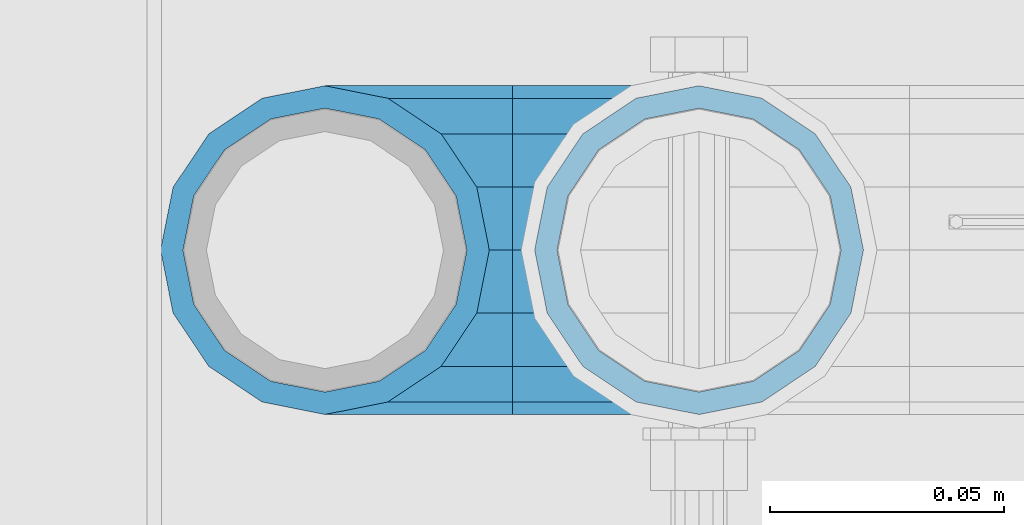
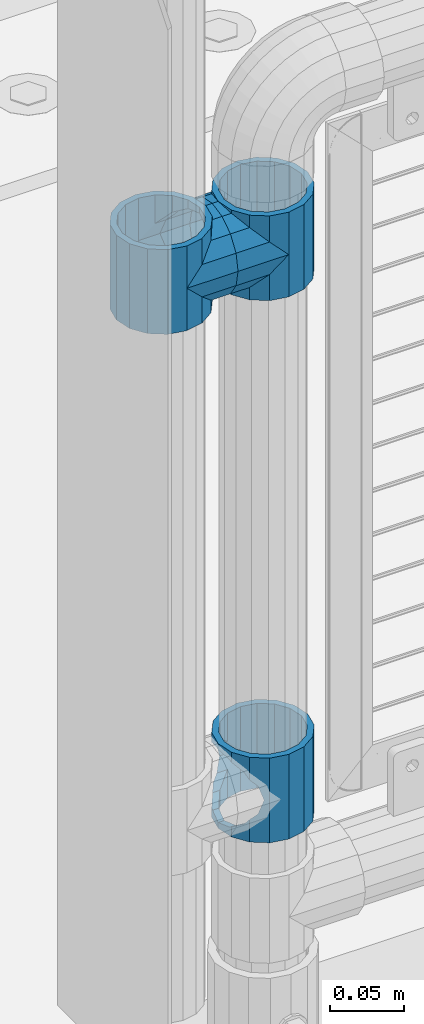
# One storey, part 109 of 193: 5 beams.
"""IFC2X3 building model written with IfcOpenShell, lengths in millimetres."""

from ifc_helpers import new_model, si_unit, frame, origin_with_axes, place, context, subcontext, project, spatial, faceted_brep, material, type_object, element, save


model = new_model("IFC2X3")

# Units and contexts
model_context = context("Model", 3, precision=1e-05, world=origin_with_axes())
body_context = subcontext(model_context, "Body", "Model", "MODEL_VIEW")
ifc_project = project(units=[si_unit("LENGTHUNIT", "METRE", prefix="MILLI"), si_unit("AREAUNIT", "SQUARE_METRE"), si_unit("VOLUMEUNIT", "CUBIC_METRE"), si_unit("MASSUNIT", "GRAM", prefix="KILO"), si_unit("TIMEUNIT", "SECOND"), si_unit("PLANEANGLEUNIT", "RADIAN"), si_unit("SOLIDANGLEUNIT", "STERADIAN"), si_unit("THERMODYNAMICTEMPERATUREUNIT", "DEGREE_CELSIUS"), si_unit("LUMINOUSINTENSITYUNIT", "LUMEN")], contexts=[model_context])

# Site, building, storey
site_placement = place(None, origin_with_axes())
site = spatial("IfcSite", under=ifc_project, at=site_placement, CompositionType="ELEMENT")
building_placement = place(site_placement, origin_with_axes())
building = spatial("IfcBuilding", under=site, at=building_placement, Name="Standard", CompositionType="ELEMENT")
storey_placement = place(building_placement, origin_with_axes())
storey = spatial("IfcBuildingStorey", under=building, at=storey_placement, Name="Undefined", CompositionType="ELEMENT", Elevation=0.0)

# Beams
ifc_material = material(Name="Misc_Undefined")
beam_type = type_object("IfcBeamType", PredefinedType="NOTDEFINED")
beam_1_placement = place(storey_placement, frame((-41829.0, 28664.5, 433.820000000004), z_axis=(1.0, 0.0, 0.0), x_axis=(0.0, 0.0, -1.0)))
element("IfcBeam", 1, at=beam_1_placement, inside=storey, type_object=beam_type, material=ifc_material, context=body_context, shape_type="Brep", body=[
    faceted_brep([(46.7644421722801, 28.0397438117179, -11.614442172282), (46.7644421722801, 28.0397438117179, -20.0882031229849), (51.5310424080006, 24.8548033587067, -24.8548033587067), (56.6106908090114, 21.46069080901, -27.1226768591041), (56.6106908090114, 21.46069080901, -21.46069080901), (61.9623795176744, 13.4513226476338, -32.4743655677703), (63.1897438117172, 11.614442172282, -32.8397438117245), (63.1897438117172, 11.614442172282, -28.0397438117179), (65.4999999999997, 0.0, -35.1500000000015), (65.4999999999997, 0.0, -30.3499999999985), (63.1897438117172, -11.614442172282, -32.8397438117172), (63.1897438117172, -11.614442172282, -28.0397438117179), (61.9623795176767, -13.4513226476338, -32.4743655677703), (56.6106908090114, -21.46069080901, -27.1226768591114), (56.6106908090114, -21.46069080901, -21.46069080901), (51.5310424080006, -24.8548033587067, -24.8548033587067), (46.7644421722801, -28.0397438117179, -20.0882031229812), (46.7644421722801, -28.0397438117179, -11.614442172282), (35.1499999999996, -30.3499999999985, -16.6306603983721), (35.1500000000015, -30.35, 0.0), (23.5355578277191, -28.0397438117179, -20.0882031229812), (23.5355578277191, -28.0397438117179, -11.614442172282), (18.7689575919921, -24.8548033587067, -24.8548033587067), (13.6893091909879, -21.46069080901, -27.1226768591114), (13.6893091909879, -21.46069080901, -21.46069080901), (8.33762048232484, -13.4513226476338, -32.4743655677703), (7.11025618828211, -11.614442172282, -32.8397438117172), (7.11025618828211, -11.614442172282, -28.0397438117179), (4.79999999999961, 0.0, -35.1500000000015), (4.79999999999961, 0.0, -30.3499999999985), (7.11025618828211, 11.614442172282, -32.8397438117245), (7.11025618828211, 11.614442172282, -28.0397438117179), (8.33762048232262, 13.4513226476338, -32.4743655677703), (13.6893091909879, 21.46069080901, -27.1226768591041), (13.6893091909879, 21.46069080901, -21.46069080901), (18.7689575919987, 24.8548033587067, -24.8548033587067), (23.5355578277192, 28.0397438117179, -20.0882031229849), (23.5355578277192, 28.0397438117179, -11.614442172282), (35.1499999999996, 30.3499999999985, -16.6306603983685), (35.1500000000015, 30.35, 0.0), (0.0, 32.4743655677703, -13.4513226476338), (0.0, 35.1500000000015, 0.0), (70.2999999999993, 35.1500000000015, 0.0), (70.2999999999993, 32.4743655677703, -13.4513226476338), (0.0, 32.4743655677703, 13.4513226476338), (70.2999999999993, 32.4743655677703, 13.4513226476338), (0.0, 24.8548033587067, 24.8548033587067), (70.2999999999993, 24.8548033587067, 24.8548033587067), (0.0, 13.4513226476338, 32.4743655677703), (70.2999999999993, 13.4513226476338, 32.4743655677703), (0.0, 0.0, 35.1500000000015), (70.2999999999993, 0.0, 35.1500000000015), (0.0, -13.4513226476338, 32.4743655677703), (70.2999999999993, -13.4513226476338, 32.4743655677703), (0.0, -24.8548033587067, 24.8548033587067), (70.2999999999993, -24.8548033587067, 24.8548033587067), (0.0, -32.4743655677703, 13.4513226476338), (70.2999999999993, -32.4743655677703, 13.4513226476338), (0.0, -35.1500000000015, 0.0), (70.2999999999993, -35.1500000000015, 0.0), (70.2999999999993, -30.3499999999985, 0.0), (70.2999999999993, -28.0397438117179, -11.614442172282), (70.2999999999993, -21.46069080901, -21.46069080901), (70.2999999999993, -11.614442172282, -28.0397438117179), (70.2999999999993, 0.0, -30.3499999999985), (70.2999999999993, 11.614442172282, -28.0397438117179), (70.2999999999993, 21.46069080901, -21.46069080901), (70.2999999999993, 28.0397438117179, -11.614442172282), (0.0, -28.0397438117179, -11.614442172282), (0.0, -30.3499999999985, 0.0), (0.0, -21.46069080901, -21.46069080901), (0.0, -11.614442172282, -28.0397438117179), (0.0, 0.0, -30.3499999999985), (0.0, 11.614442172282, -28.0397438117179), (0.0, 21.46069080901, -21.46069080901), (0.0, 28.0397438117179, -11.614442172282), (0.0, 30.3499999999985, 0.0), (70.2999999999993, 30.3499999999985, 0.0), (0.0, 28.0397438117179, 11.614442172282), (70.2999999999993, 28.0397438117179, 11.614442172282), (0.0, 21.46069080901, 21.46069080901), (70.2999999999993, 21.46069080901, 21.46069080901), (0.0, 11.614442172282, 28.0397438117179), (70.2999999999993, 11.614442172282, 28.0397438117179), (0.0, 0.0, 30.3499999999985), (70.2999999999993, 0.0, 30.3499999999985), (0.0, -11.614442172282, 28.0397438117179), (70.2999999999993, -11.614442172282, 28.0397438117179), (0.0, -21.46069080901, 21.46069080901), (70.2999999999993, -21.46069080901, 21.46069080901), (0.0, -28.0397438117179, 11.614442172282), (70.2999999999993, -28.0397438117179, 11.614442172282), (70.2999999999993, -24.8548033587067, -24.8548033587067), (70.2999999999993, -13.4513226476338, -32.4743655677703), (70.2999999999993, 0.0, -35.1500000000015), (70.2999999999993, 13.4513226476338, -32.4743655677703), (70.2999999999993, 24.8548033587067, -24.8548033587067), (70.2999999999993, -32.4743655677703, -13.4513226476338), (0.0, -32.4743655677703, -13.4513226476338), (0.0, 24.8548033587067, -24.8548033587067), (0.0, 13.4513226476338, -32.4743655677703), (0.0, 0.0, -35.1500000000015), (0.0, -13.4513226476338, -32.4743655677703), (0.0, -24.8548033587067, -24.8548033587067)], [[[0, 1, 2, 3, 4]], [[4, 3, 5, 6, 7]], [[7, 6, 8, 9]], [[9, 8, 10, 11]], [[11, 10, 12, 13, 14]], [[14, 13, 15, 16, 17]], [[17, 16, 18, 19]], [[19, 18, 20, 21]], [[21, 20, 22, 23, 24]], [[24, 23, 25, 26, 27]], [[27, 26, 28, 29]], [[29, 28, 30, 31]], [[31, 30, 32, 33, 34]], [[34, 33, 35, 36, 37]], [[37, 36, 38, 39]], [[39, 38, 1, 0]], [[40, 41, 42, 43]], [[41, 44, 45, 42]], [[44, 46, 47, 45]], [[46, 48, 49, 47]], [[48, 50, 51, 49]], [[50, 52, 53, 51]], [[52, 54, 55, 53]], [[54, 56, 57, 55]], [[56, 58, 59, 57]], [[60, 61, 17, 19]], [[61, 62, 14, 17]], [[62, 63, 11, 14]], [[63, 64, 9, 11]], [[64, 65, 7, 9]], [[65, 66, 4, 7]], [[66, 67, 0, 4]], [[68, 69, 19, 21]], [[70, 68, 21, 24]], [[71, 70, 24, 27]], [[72, 71, 27, 29]], [[73, 72, 29, 31]], [[74, 73, 31, 34]], [[75, 74, 34, 37]], [[76, 75, 37, 39]], [[67, 77, 39, 0]], [[78, 76, 39, 77, 79]], [[80, 78, 79, 81]], [[82, 80, 81, 83]], [[84, 82, 83, 85]], [[86, 84, 85, 87]], [[88, 86, 87, 89]], [[90, 88, 89, 91]], [[19, 69, 90, 91, 60]], [[92, 93, 94, 95, 96, 43, 42, 45, 47, 49, 51, 53, 55, 57, 59, 97], [89, 87, 85, 83, 81, 79, 77, 67, 66, 65, 64, 63, 62, 61, 60, 91]], [[58, 98, 97, 59]], [[56, 54, 52, 50, 48, 46, 44, 41, 40, 99, 100, 101, 102, 103, 98, 58], [68, 70, 71, 72, 73, 74, 75, 76, 78, 80, 82, 84, 86, 88, 90, 69]], [[32, 100, 99, 35, 33]], [[28, 101, 100, 32, 30]], [[102, 101, 28, 26, 25]], [[103, 102, 25, 23, 22]], [[15, 92, 97, 98, 103, 22, 20, 18, 16]], [[12, 93, 92, 15, 13]], [[8, 94, 93, 12, 10]], [[95, 94, 8, 6, 5]], [[96, 95, 5, 3, 2]], [[35, 99, 40, 43, 96, 2, 1, 38, 36]]]),
])
beam_2_placement = place(storey_placement, frame((-41909.0, 28664.5, 848.670000000005), z_axis=(0.0, -1.0, 0.0), x_axis=(1.0, 0.0, 0.0)))
element("IfcBeam", 2, at=beam_2_placement, inside=storey, type_object=beam_type, material=ifc_material, context=body_context, shape_type="Brep", body=[
    faceted_brep([(0.0, 0.0, -35.1500000000015), (13.4513226476338, -13.4513226476329, -32.4743655677703), (13.4513226476338, 13.4513226476329, -32.4743655677703), (32.4743655677703, 32.4743655677717, 13.4513226476338), (32.4743655677703, 26.8123795176754, 13.4513226476338), (27.1226768591041, 21.4606908090117, 21.46069080901), (24.8548033587067, 16.3810424080078, 24.8548033587067), (24.8548033587067, 24.8548033587072, 24.8548033587067), (0.0, 0.0, 35.1500000000015), (13.4513226476338, 13.4513226476329, 32.4743655677703), (13.4513226476338, -13.4513226476329, 32.4743655677703), (20.0882031229849, 11.6144421722805, 28.0397438117179), (16.6306603983685, 0.0, 30.3499999999985), (20.0882031229849, -11.6144421722805, 28.0397438117179), (24.8548033587067, -16.3810424080013, 24.8548033587067), (24.8548033587067, -24.8548033587072, 24.8548033587067), (27.1226768591041, -21.4606908090117, 21.46069080901), (32.4743655677703, -26.8123795176776, 13.4513226476338), (32.4743655677703, -32.4743655677717, 13.4513226476338), (32.8397438117208, -28.0397438117175, 11.614442172282), (35.1500000000015, -30.35, 0.0), (35.1500000000015, -35.15, 0.0), (32.4743655677703, -26.8123795176754, -13.4513226476338), (32.4743655677703, -32.4743655677717, -13.4513226476338), (32.8397438117172, -28.0397438117175, -11.614442172282), (24.8548033587067, -16.3810424080013, -24.8548033587067), (24.8548033587067, -24.8548033587072, -24.8548033587067), (27.1226768591114, -21.4606908090117, -21.46069080901), (20.0882031229849, -11.6144421722805, -28.0397438117179), (16.6306603983721, 0.0, -30.3499999999985), (20.0882031229849, 11.6144421722805, -28.0397438117179), (24.8548033587067, 16.3810424080013, -24.8548033587067), (24.8548033587067, 24.8548033587072, -24.8548033587067), (27.1226768591114, 21.4606908090117, -21.46069080901), (32.4743655677703, 26.8123795176776, -13.4513226476338), (32.4743655677703, 32.4743655677717, -13.4513226476338), (32.8397438117172, 28.0397438117175, -11.614442172282), (35.1500000000015, 30.35, 0.0), (35.1500000000015, 35.15, 0.0), (32.8397438117208, 28.0397438117175, 11.614442172282), (40.1500000000015, -35.15, 0.0), (40.1500000000015, -32.4743655677718, 13.4513226476338), (40.1500000000015, -24.8548033587072, 24.8548033587067), (40.1500000000015, -13.4513226476329, 32.4743655677703), (40.1500000000015, 0.0, 35.1500000000015), (40.1500000000015, 13.4513226476329, 32.4743655677703), (40.1500000000015, 24.8548033587072, 24.8548033587067), (40.1500000000015, 32.4743655677718, 13.4513226476338), (40.1500000000015, 35.15, 0.0), (40.1500000000015, -24.8548033587072, -24.8548033587067), (40.1500000000015, -32.4743655677718, -13.4513226476338), (40.1500000000015, -13.4513226476329, -32.4743655677703), (40.1500000000015, 0.0, -35.1500000000015), (40.1500000000015, 13.4513226476329, -32.4743655677703), (40.1500000000015, 24.8548033587072, -24.8548033587067), (40.1500000000015, 32.4743655677718, -13.4513226476338), (40.1500000000015, -21.4606908090117, 21.46069080901), (40.1500000000015, -11.6144421722805, 28.0397438117179), (40.1500000000015, 0.0, 30.3499999999985), (40.1500000000015, 11.6144421722805, 28.0397438117179), (40.1500000000015, 21.4606908090117, 21.46069080901), (40.1500000000015, 28.0397438117176, 11.614442172282), (40.1500000000015, 30.35, 0.0), (40.1500000000015, 28.0397438117176, -11.614442172282), (40.1500000000015, 21.4606908090117, -21.46069080901), (40.1500000000015, 11.6144421722805, -28.0397438117179), (40.1500000000015, 0.0, -30.3499999999985), (40.1500000000015, -11.6144421722805, -28.0397438117179), (40.1500000000015, -21.4606908090117, -21.46069080901), (40.1500000000015, -28.0397438117176, -11.614442172282), (40.1500000000015, -30.35, 0.0), (40.1500000000015, -28.0397438117176, 11.614442172282)], [[[0, 1, 2]], [[3, 4, 5, 6, 7]], [[8, 9, 10]], [[7, 6, 11, 12, 13, 14, 15, 10, 9]], [[16, 17, 18, 15, 14]], [[19, 20, 21, 18, 17]], [[22, 23, 21, 20, 24]], [[25, 26, 23, 22, 27]], [[2, 1, 26, 25, 28, 29, 30, 31, 32]], [[32, 31, 33, 34, 35]], [[35, 34, 36, 37, 38]], [[38, 37, 39, 4, 3]], [[40, 41, 18, 21]], [[41, 42, 15, 18]], [[42, 43, 10, 15]], [[43, 44, 8, 10]], [[44, 45, 9, 8]], [[45, 46, 7, 9]], [[46, 47, 3, 7]], [[47, 48, 38, 3]], [[49, 50, 23, 26]], [[51, 49, 26, 1]], [[52, 51, 1, 0]], [[53, 52, 0, 2]], [[54, 53, 2, 32]], [[55, 54, 32, 35]], [[48, 55, 35, 38]], [[50, 40, 21, 23]], [[49, 51, 52, 53, 54, 55, 48, 47, 46, 45, 44, 43, 42, 41, 40, 50], [56, 57, 58, 59, 60, 61, 62, 63, 64, 65, 66, 67, 68, 69, 70, 71]], [[63, 62, 37, 36]], [[33, 64, 63, 36, 34]], [[30, 65, 64, 33, 31]], [[66, 65, 30, 29]], [[67, 66, 29, 28]], [[68, 67, 28, 25, 27]], [[69, 68, 27, 22, 24]], [[70, 69, 24, 20]], [[71, 70, 20, 19]], [[16, 56, 71, 19, 17]], [[13, 57, 56, 16, 14]], [[58, 57, 13, 12]], [[59, 58, 12, 11]], [[60, 59, 11, 6, 5]], [[61, 60, 5, 4, 39]], [[62, 61, 39, 37]]]),
])
beam_3_placement = place(storey_placement, frame((-41829.0, 28664.5, 848.670000000005), z_axis=(0.0, 1.0, 0.0), x_axis=(-1.0, 0.0, 0.0)))
element("IfcBeam", 3, at=beam_3_placement, inside=storey, type_object=beam_type, material=ifc_material, context=body_context, shape_type="Brep", body=[
    faceted_brep([(0.0, 0.0, -35.1500000000015), (13.4513226476338, -13.4513226476329, -32.4743655677703), (13.4513226476338, 13.4513226476329, -32.4743655677703), (27.1226768591041, -21.4606908090117, 21.46069080901), (32.4743655677703, -26.8123795176776, 13.4513226476338), (32.4743655677703, -32.4743655677717, 13.4513226476338), (24.8548033587067, -24.8548033587072, 24.8548033587067), (24.8548033587067, -16.3810424080013, 24.8548033587067), (32.8397438117208, -28.0397438117175, 11.614442172282), (35.1500000000015, -30.35, 0.0), (35.1500000000015, -35.15, 0.0), (32.4743655677703, -26.8123795176754, -13.4513226476338), (32.4743655677703, -32.4743655677717, -13.4513226476338), (32.8397438117172, -28.0397438117175, -11.614442172282), (24.8548033587067, -16.3810424080013, -24.8548033587067), (24.8548033587067, -24.8548033587072, -24.8548033587067), (27.1226768591114, -21.4606908090117, -21.46069080901), (20.0882031229849, -11.6144421722805, -28.0397438117179), (16.6306603983721, 0.0, -30.3499999999985), (20.0882031229849, 11.6144421722805, -28.0397438117179), (24.8548033587067, 16.3810424080013, -24.8548033587067), (24.8548033587067, 24.8548033587072, -24.8548033587067), (27.1226768591114, 21.4606908090117, -21.46069080901), (32.4743655677703, 26.8123795176776, -13.4513226476338), (32.4743655677703, 32.4743655677717, -13.4513226476338), (32.8397438117172, 28.0397438117175, -11.614442172282), (35.1500000000015, 30.35, 0.0), (35.1500000000015, 35.15, 0.0), (32.8397438117208, 28.0397438117175, 11.614442172282), (32.4743655677703, 26.8123795176754, 13.4513226476338), (32.4743655677703, 32.4743655677717, 13.4513226476338), (27.1226768591041, 21.4606908090117, 21.46069080901), (24.8548033587067, 16.3810424080078, 24.8548033587067), (24.8548033587067, 24.8548033587072, 24.8548033587067), (0.0, 0.0, 35.1500000000015), (13.4513226476338, 13.4513226476329, 32.4743655677703), (13.4513226476338, -13.4513226476329, 32.4743655677703), (20.0882031229849, 11.6144421722805, 28.0397438117179), (16.6306603983685, 0.0, 30.3499999999985), (20.0882031229849, -11.6144421722805, 28.0397438117179), (40.1500000000015, -35.15, 0.0), (40.1500000000015, -32.4743655677718, 13.4513226476338), (40.1500000000015, -24.8548033587072, 24.8548033587067), (40.1500000000015, -13.4513226476329, 32.4743655677703), (40.1500000000015, 0.0, 35.1500000000015), (40.1500000000015, -24.8548033587072, -24.8548033587067), (40.1500000000015, -32.4743655677718, -13.4513226476338), (40.1500000000015, -13.4513226476329, -32.4743655677703), (40.1500000000015, 0.0, -35.1500000000015), (40.1500000000015, 13.4513226476329, -32.4743655677703), (40.1500000000015, 24.8548033587072, -24.8548033587067), (40.1500000000015, 32.4743655677718, -13.4513226476338), (40.1500000000015, 35.15, 0.0), (40.1500000000015, 32.4743655677718, 13.4513226476338), (40.1500000000015, 24.8548033587072, 24.8548033587067), (40.1500000000015, 13.4513226476329, 32.4743655677703), (40.1500000000015, -21.4606908090117, 21.46069080901), (40.1500000000015, -11.6144421722805, 28.0397438117179), (40.1500000000015, 0.0, 30.3499999999985), (40.1500000000015, 11.6144421722805, 28.0397438117179), (40.1500000000015, 21.4606908090117, 21.46069080901), (40.1500000000015, 28.0397438117176, 11.614442172282), (40.1500000000015, 30.35, 0.0), (40.1500000000015, 28.0397438117176, -11.614442172282), (40.1500000000015, 21.4606908090117, -21.46069080901), (40.1500000000015, 11.6144421722805, -28.0397438117179), (40.1500000000015, 0.0, -30.3499999999985), (40.1500000000015, -11.6144421722805, -28.0397438117179), (40.1500000000015, -21.4606908090117, -21.46069080901), (40.1500000000015, -28.0397438117176, -11.614442172282), (40.1500000000015, -30.35, 0.0), (40.1500000000015, -28.0397438117176, 11.614442172282)], [[[0, 1, 2]], [[3, 4, 5, 6, 7]], [[8, 9, 10, 5, 4]], [[11, 12, 10, 9, 13]], [[14, 15, 12, 11, 16]], [[2, 1, 15, 14, 17, 18, 19, 20, 21]], [[21, 20, 22, 23, 24]], [[24, 23, 25, 26, 27]], [[27, 26, 28, 29, 30]], [[30, 29, 31, 32, 33]], [[34, 35, 36]], [[33, 32, 37, 38, 39, 7, 6, 36, 35]], [[40, 41, 5, 10]], [[41, 42, 6, 5]], [[42, 43, 36, 6]], [[43, 44, 34, 36]], [[45, 46, 12, 15]], [[47, 45, 15, 1]], [[48, 47, 1, 0]], [[49, 48, 0, 2]], [[50, 49, 2, 21]], [[51, 50, 21, 24]], [[52, 51, 24, 27]], [[53, 52, 27, 30]], [[54, 53, 30, 33]], [[55, 54, 33, 35]], [[44, 55, 35, 34]], [[46, 40, 10, 12]], [[45, 47, 48, 49, 50, 51, 52, 53, 54, 55, 44, 43, 42, 41, 40, 46], [56, 57, 58, 59, 60, 61, 62, 63, 64, 65, 66, 67, 68, 69, 70, 71]], [[59, 58, 38, 37]], [[60, 59, 37, 32, 31]], [[61, 60, 31, 29, 28]], [[62, 61, 28, 26]], [[63, 62, 26, 25]], [[22, 64, 63, 25, 23]], [[19, 65, 64, 22, 20]], [[66, 65, 19, 18]], [[67, 66, 18, 17]], [[68, 67, 17, 14, 16]], [[69, 68, 16, 11, 13]], [[70, 69, 13, 9]], [[71, 70, 9, 8]], [[3, 56, 71, 8, 4]], [[39, 57, 56, 3, 7]], [[58, 57, 39, 38]]]),
])
beam_4_placement = place(storey_placement, frame((-41909.0, 28664.5, 883.820000000004), z_axis=(-1.0, 0.0, 0.0), x_axis=(0.0, 0.0, -1.0)))
element("IfcBeam", 4, at=beam_4_placement, inside=storey, type_object=beam_type, material=ifc_material, context=body_context, shape_type="Brep", body=[
    faceted_brep([(13.6893091909879, -21.46069080901, -21.46069080901), (13.6893091909879, -21.46069080901, -27.1226768591114), (8.33762048232484, -13.4513226476338, -32.4743655677703), (7.11025618828211, -11.614442172282, -32.8397438117172), (7.11025618828211, -11.614442172282, -28.0397438117179), (23.5355578277191, -28.0397438117179, -11.614442172282), (23.5355578277191, -28.0397438117179, -20.0882031229812), (18.7689575919921, -24.8548033587067, -24.8548033587067), (35.1500000000015, -30.35, 0.0), (35.1499999999996, -30.3499999999985, -16.6306603983721), (46.7644421722801, -28.0397438117179, -11.614442172282), (46.7644421722801, -28.0397438117179, -20.0882031229812), (56.6106908090114, -21.46069080901, -21.46069080901), (56.6106908090114, -21.46069080901, -27.1226768591114), (51.5310424080006, -24.8548033587067, -24.8548033587067), (63.1897438117172, -11.614442172282, -28.0397438117179), (63.1897438117172, -11.614442172282, -32.8397438117172), (61.9623795176767, -13.4513226476338, -32.4743655677703), (65.4999999999997, 0.0, -30.3499999999985), (65.4999999999997, 0.0, -35.1500000000015), (63.1897438117172, 11.614442172282, -28.0397438117179), (63.1897438117172, 11.614442172282, -32.8397438117245), (56.6106908090114, 21.46069080901, -21.46069080901), (56.6106908090114, 21.46069080901, -27.1226768591041), (61.9623795176744, 13.4513226476338, -32.4743655677703), (46.7644421722801, 28.0397438117179, -11.614442172282), (46.7644421722801, 28.0397438117179, -20.0882031229849), (51.5310424080006, 24.8548033587067, -24.8548033587067), (35.1500000000015, 30.35, 0.0), (35.1499999999996, 30.3499999999985, -16.6306603983685), (23.5355578277192, 28.0397438117179, -11.614442172282), (23.5355578277192, 28.0397438117179, -20.0882031229849), (13.6893091909879, 21.46069080901, -21.46069080901), (13.6893091909879, 21.46069080901, -27.1226768591041), (18.7689575919987, 24.8548033587067, -24.8548033587067), (7.11025618828211, 11.614442172282, -28.0397438117179), (7.11025618828211, 11.614442172282, -32.8397438117245), (8.33762048232262, 13.4513226476338, -32.4743655677703), (4.79999999999961, 0.0, -30.3499999999985), (4.79999999999961, 0.0, -35.1500000000015), (0.0, 21.46069080901, 21.46069080901), (0.0, 28.0397438117179, 11.614442172282), (70.2999999999993, 28.0397438117179, 11.614442172282), (70.2999999999993, 21.46069080901, 21.46069080901), (0.0, 11.614442172282, 28.0397438117179), (70.2999999999993, 11.614442172282, 28.0397438117179), (0.0, 0.0, 30.3499999999985), (70.2999999999993, 0.0, 30.3499999999985), (0.0, -11.614442172282, 28.0397438117179), (70.2999999999993, -11.614442172282, 28.0397438117179), (0.0, -21.46069080901, 21.46069080901), (70.2999999999993, -21.46069080901, 21.46069080901), (0.0, -28.0397438117179, 11.614442172282), (70.2999999999993, -28.0397438117179, 11.614442172282), (0.0, -24.8548033587067, -24.8548033587067), (0.0, -13.4513226476338, -32.4743655677703), (0.0, 0.0, -35.1500000000015), (0.0, -32.4743655677703, 13.4513226476338), (0.0, -35.1500000000015, 0.0), (70.2999999999993, -35.1500000000015, 0.0), (70.2999999999993, -32.4743655677703, 13.4513226476338), (0.0, -24.8548033587067, 24.8548033587067), (70.2999999999993, -24.8548033587067, 24.8548033587067), (0.0, -13.4513226476338, 32.4743655677703), (70.2999999999993, -13.4513226476338, 32.4743655677703), (0.0, 0.0, 35.1500000000015), (70.2999999999993, 0.0, 35.1500000000015), (0.0, 13.4513226476338, 32.4743655677703), (70.2999999999993, 13.4513226476338, 32.4743655677703), (0.0, 24.8548033587067, 24.8548033587067), (70.2999999999993, 24.8548033587067, 24.8548033587067), (0.0, 32.4743655677703, 13.4513226476338), (70.2999999999993, 32.4743655677703, 13.4513226476338), (0.0, 35.1500000000015, 0.0), (70.2999999999993, 35.1500000000015, 0.0), (0.0, 32.4743655677703, -13.4513226476338), (70.2999999999993, 32.4743655677703, -13.4513226476338), (70.2999999999993, -13.4513226476338, -32.4743655677703), (70.2999999999993, -24.8548033587067, -24.8548033587067), (70.2999999999993, 0.0, -35.1500000000015), (70.2999999999993, 13.4513226476338, -32.4743655677703), (70.2999999999993, 24.8548033587067, -24.8548033587067), (0.0, 24.8548033587067, -24.8548033587067), (0.0, 13.4513226476338, -32.4743655677703), (70.2999999999993, -32.4743655677703, -13.4513226476338), (0.0, -32.4743655677703, -13.4513226476338), (0.0, -28.0397438117179, -11.614442172282), (0.0, -21.46069080901, -21.46069080901), (0.0, -11.614442172282, -28.0397438117179), (0.0, 0.0, -30.3499999999985), (0.0, 11.614442172282, -28.0397438117179), (0.0, 21.46069080901, -21.46069080901), (0.0, 28.0397438117179, -11.614442172282), (0.0, 30.3499999999985, 0.0), (0.0, -30.3499999999985, 0.0), (70.2999999999993, 30.3499999999985, 0.0), (70.2999999999993, 28.0397438117179, -11.614442172282), (70.2999999999993, 21.46069080901, -21.46069080901), (70.2999999999993, 11.614442172282, -28.0397438117179), (70.2999999999993, 0.0, -30.3499999999985), (70.2999999999993, -11.614442172282, -28.0397438117179), (70.2999999999993, -21.46069080901, -21.46069080901), (70.2999999999993, -28.0397438117179, -11.614442172282), (70.2999999999993, -30.3499999999985, 0.0)], [[[0, 1, 2, 3, 4]], [[5, 6, 7, 1, 0]], [[8, 9, 6, 5]], [[10, 11, 9, 8]], [[12, 13, 14, 11, 10]], [[15, 16, 17, 13, 12]], [[18, 19, 16, 15]], [[20, 21, 19, 18]], [[22, 23, 24, 21, 20]], [[25, 26, 27, 23, 22]], [[28, 29, 26, 25]], [[30, 31, 29, 28]], [[32, 33, 34, 31, 30]], [[35, 36, 37, 33, 32]], [[38, 39, 36, 35]], [[4, 3, 39, 38]], [[40, 41, 42, 43]], [[44, 40, 43, 45]], [[46, 44, 45, 47]], [[48, 46, 47, 49]], [[50, 48, 49, 51]], [[52, 50, 51, 53]], [[54, 55, 2, 1, 7]], [[55, 56, 39, 3, 2]], [[57, 58, 59, 60]], [[61, 57, 60, 62]], [[63, 61, 62, 64]], [[65, 63, 64, 66]], [[67, 65, 66, 68]], [[69, 67, 68, 70]], [[71, 69, 70, 72]], [[73, 71, 72, 74]], [[75, 73, 74, 76]], [[17, 77, 78, 14, 13]], [[19, 79, 77, 17, 16]], [[80, 79, 19, 21, 24]], [[81, 80, 24, 23, 27]], [[34, 82, 75, 76, 81, 27, 26, 29, 31]], [[37, 83, 82, 34, 33]], [[39, 56, 83, 37, 36]], [[14, 78, 84, 85, 54, 7, 6, 9, 11]], [[58, 85, 84, 59]], [[57, 61, 63, 65, 67, 69, 71, 73, 75, 82, 83, 56, 55, 54, 85, 58], [86, 87, 88, 89, 90, 91, 92, 93, 41, 40, 44, 46, 48, 50, 52, 94]], [[90, 89, 38, 35]], [[91, 90, 35, 32]], [[92, 91, 32, 30]], [[93, 92, 30, 28]], [[41, 93, 28, 95, 42]], [[96, 95, 28, 25]], [[97, 96, 25, 22]], [[98, 97, 22, 20]], [[99, 98, 20, 18]], [[100, 99, 18, 15]], [[101, 100, 15, 12]], [[102, 101, 12, 10]], [[103, 102, 10, 8]], [[78, 77, 79, 80, 81, 76, 74, 72, 70, 68, 66, 64, 62, 60, 59, 84], [51, 49, 47, 45, 43, 42, 95, 96, 97, 98, 99, 100, 101, 102, 103, 53]], [[8, 94, 52, 53, 103]], [[86, 94, 8, 5]], [[87, 86, 5, 0]], [[88, 87, 0, 4]], [[89, 88, 4, 38]]]),
])
beam_5_placement = place(storey_placement, frame((-41829.0, 28664.5, 883.820000000004), z_axis=(1.0, 0.0, 0.0), x_axis=(0.0, 0.0, -1.0)))
element("IfcBeam", 5, at=beam_5_placement, inside=storey, type_object=beam_type, material=ifc_material, context=body_context, shape_type="Brep", body=[
    faceted_brep([(46.7644421722801, 28.0397438117179, -11.614442172282), (46.7644421722801, 28.0397438117179, -20.0882031229849), (51.5310424080006, 24.8548033587067, -24.8548033587067), (56.6106908090114, 21.46069080901, -27.1226768591041), (56.6106908090114, 21.46069080901, -21.46069080901), (61.9623795176744, 13.4513226476338, -32.4743655677703), (63.1897438117172, 11.614442172282, -32.8397438117245), (63.1897438117172, 11.614442172282, -28.0397438117179), (65.4999999999997, 0.0, -35.1500000000015), (65.4999999999997, 0.0, -30.3499999999985), (63.1897438117172, -11.614442172282, -32.8397438117172), (63.1897438117172, -11.614442172282, -28.0397438117179), (61.9623795176767, -13.4513226476338, -32.4743655677703), (56.6106908090114, -21.46069080901, -27.1226768591114), (56.6106908090114, -21.46069080901, -21.46069080901), (51.5310424080006, -24.8548033587067, -24.8548033587067), (46.7644421722801, -28.0397438117179, -20.0882031229812), (46.7644421722801, -28.0397438117179, -11.614442172282), (35.1499999999996, -30.3499999999985, -16.6306603983721), (35.1500000000015, -30.35, 0.0), (23.5355578277191, -28.0397438117179, -20.0882031229812), (23.5355578277191, -28.0397438117179, -11.614442172282), (18.7689575919921, -24.8548033587067, -24.8548033587067), (13.6893091909879, -21.46069080901, -27.1226768591114), (13.6893091909879, -21.46069080901, -21.46069080901), (8.33762048232484, -13.4513226476338, -32.4743655677703), (7.11025618828211, -11.614442172282, -32.8397438117172), (7.11025618828211, -11.614442172282, -28.0397438117179), (4.79999999999961, 0.0, -35.1500000000015), (4.79999999999961, 0.0, -30.3499999999985), (7.11025618828211, 11.614442172282, -32.8397438117245), (7.11025618828211, 11.614442172282, -28.0397438117179), (8.33762048232262, 13.4513226476338, -32.4743655677703), (13.6893091909879, 21.46069080901, -27.1226768591041), (13.6893091909879, 21.46069080901, -21.46069080901), (18.7689575919987, 24.8548033587067, -24.8548033587067), (23.5355578277192, 28.0397438117179, -20.0882031229849), (23.5355578277192, 28.0397438117179, -11.614442172282), (35.1499999999996, 30.3499999999985, -16.6306603983685), (35.1500000000015, 30.35, 0.0), (0.0, 32.4743655677703, -13.4513226476338), (0.0, 35.1500000000015, 0.0), (70.2999999999993, 35.1500000000015, 0.0), (70.2999999999993, 32.4743655677703, -13.4513226476338), (0.0, 32.4743655677703, 13.4513226476338), (70.2999999999993, 32.4743655677703, 13.4513226476338), (0.0, 24.8548033587067, 24.8548033587067), (70.2999999999993, 24.8548033587067, 24.8548033587067), (0.0, 13.4513226476338, 32.4743655677703), (70.2999999999993, 13.4513226476338, 32.4743655677703), (0.0, 0.0, 35.1500000000015), (70.2999999999993, 0.0, 35.1500000000015), (0.0, -13.4513226476338, 32.4743655677703), (70.2999999999993, -13.4513226476338, 32.4743655677703), (0.0, -24.8548033587067, 24.8548033587067), (70.2999999999993, -24.8548033587067, 24.8548033587067), (0.0, -32.4743655677703, 13.4513226476338), (70.2999999999993, -32.4743655677703, 13.4513226476338), (0.0, -35.1500000000015, 0.0), (70.2999999999993, -35.1500000000015, 0.0), (70.2999999999993, -30.3499999999985, 0.0), (70.2999999999993, -28.0397438117179, -11.614442172282), (70.2999999999993, -21.46069080901, -21.46069080901), (70.2999999999993, -11.614442172282, -28.0397438117179), (70.2999999999993, 0.0, -30.3499999999985), (70.2999999999993, 11.614442172282, -28.0397438117179), (70.2999999999993, 21.46069080901, -21.46069080901), (70.2999999999993, 28.0397438117179, -11.614442172282), (0.0, -28.0397438117179, -11.614442172282), (0.0, -30.3499999999985, 0.0), (0.0, -21.46069080901, -21.46069080901), (0.0, -11.614442172282, -28.0397438117179), (0.0, 0.0, -30.3499999999985), (0.0, 11.614442172282, -28.0397438117179), (0.0, 21.46069080901, -21.46069080901), (0.0, 28.0397438117179, -11.614442172282), (0.0, 30.3499999999985, 0.0), (70.2999999999993, 30.3499999999985, 0.0), (0.0, 28.0397438117179, 11.614442172282), (70.2999999999993, 28.0397438117179, 11.614442172282), (0.0, 21.46069080901, 21.46069080901), (70.2999999999993, 21.46069080901, 21.46069080901), (0.0, 11.614442172282, 28.0397438117179), (70.2999999999993, 11.614442172282, 28.0397438117179), (0.0, 0.0, 30.3499999999985), (70.2999999999993, 0.0, 30.3499999999985), (0.0, -11.614442172282, 28.0397438117179), (70.2999999999993, -11.614442172282, 28.0397438117179), (0.0, -21.46069080901, 21.46069080901), (70.2999999999993, -21.46069080901, 21.46069080901), (0.0, -28.0397438117179, 11.614442172282), (70.2999999999993, -28.0397438117179, 11.614442172282), (70.2999999999993, -24.8548033587067, -24.8548033587067), (70.2999999999993, -13.4513226476338, -32.4743655677703), (70.2999999999993, 0.0, -35.1500000000015), (70.2999999999993, 13.4513226476338, -32.4743655677703), (70.2999999999993, 24.8548033587067, -24.8548033587067), (70.2999999999993, -32.4743655677703, -13.4513226476338), (0.0, -32.4743655677703, -13.4513226476338), (0.0, 24.8548033587067, -24.8548033587067), (0.0, 13.4513226476338, -32.4743655677703), (0.0, 0.0, -35.1500000000015), (0.0, -13.4513226476338, -32.4743655677703), (0.0, -24.8548033587067, -24.8548033587067)], [[[0, 1, 2, 3, 4]], [[4, 3, 5, 6, 7]], [[7, 6, 8, 9]], [[9, 8, 10, 11]], [[11, 10, 12, 13, 14]], [[14, 13, 15, 16, 17]], [[17, 16, 18, 19]], [[19, 18, 20, 21]], [[21, 20, 22, 23, 24]], [[24, 23, 25, 26, 27]], [[27, 26, 28, 29]], [[29, 28, 30, 31]], [[31, 30, 32, 33, 34]], [[34, 33, 35, 36, 37]], [[37, 36, 38, 39]], [[39, 38, 1, 0]], [[40, 41, 42, 43]], [[41, 44, 45, 42]], [[44, 46, 47, 45]], [[46, 48, 49, 47]], [[48, 50, 51, 49]], [[50, 52, 53, 51]], [[52, 54, 55, 53]], [[54, 56, 57, 55]], [[56, 58, 59, 57]], [[60, 61, 17, 19]], [[61, 62, 14, 17]], [[62, 63, 11, 14]], [[63, 64, 9, 11]], [[64, 65, 7, 9]], [[65, 66, 4, 7]], [[66, 67, 0, 4]], [[68, 69, 19, 21]], [[70, 68, 21, 24]], [[71, 70, 24, 27]], [[72, 71, 27, 29]], [[73, 72, 29, 31]], [[74, 73, 31, 34]], [[75, 74, 34, 37]], [[76, 75, 37, 39]], [[67, 77, 39, 0]], [[78, 76, 39, 77, 79]], [[80, 78, 79, 81]], [[82, 80, 81, 83]], [[84, 82, 83, 85]], [[86, 84, 85, 87]], [[88, 86, 87, 89]], [[90, 88, 89, 91]], [[19, 69, 90, 91, 60]], [[92, 93, 94, 95, 96, 43, 42, 45, 47, 49, 51, 53, 55, 57, 59, 97], [89, 87, 85, 83, 81, 79, 77, 67, 66, 65, 64, 63, 62, 61, 60, 91]], [[58, 98, 97, 59]], [[56, 54, 52, 50, 48, 46, 44, 41, 40, 99, 100, 101, 102, 103, 98, 58], [68, 70, 71, 72, 73, 74, 75, 76, 78, 80, 82, 84, 86, 88, 90, 69]], [[32, 100, 99, 35, 33]], [[28, 101, 100, 32, 30]], [[102, 101, 28, 26, 25]], [[103, 102, 25, 23, 22]], [[15, 92, 97, 98, 103, 22, 20, 18, 16]], [[12, 93, 92, 15, 13]], [[8, 94, 93, 12, 10]], [[95, 94, 8, 6, 5]], [[96, 95, 5, 3, 2]], [[35, 99, 40, 43, 96, 2, 1, 38, 36]]]),
])

save(model, "model.ifc")
